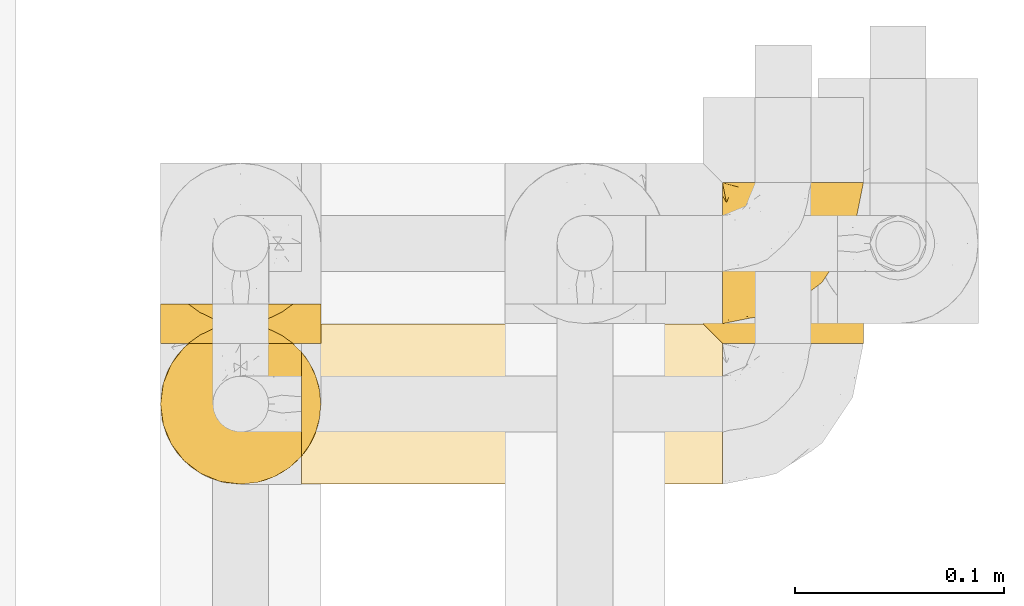
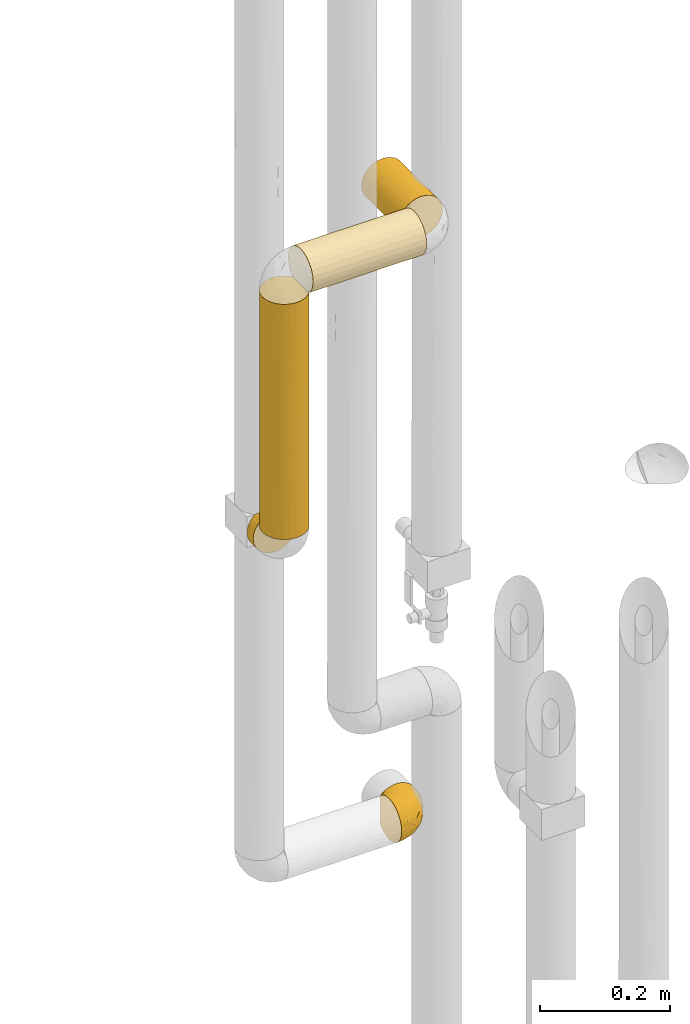
# One storey, part 288 of 827: 5 coverings.
"""IFC2X3 building model written with IfcOpenShell, lengths in millimetres."""

from ifc_helpers import new_model, entity, si_unit, converted_unit, derived_unit, direction, frame, origin, place, context, subcontext, project, spatial, faceted_brep, element, save


model = new_model("IFC2X3")

# Units and contexts
model_context = context("Model", 3, precision=0.01, world=origin(), true_north=direction((6.12303176911189e-17, 1.0)))
body_context = subcontext(model_context, "Body", "Model", "MODEL_VIEW")
ifc_project = project(units=[si_unit("LENGTHUNIT", "METRE", prefix="MILLI"), si_unit("AREAUNIT", "SQUARE_METRE"), si_unit("VOLUMEUNIT", "CUBIC_METRE"), converted_unit("PLANEANGLEUNIT", "DEGREE", entity("IfcRatioMeasure", 0.0174532925199433), si_unit("PLANEANGLEUNIT", "RADIAN"), dimensions=[0, 0, 0, 0, 0, 0, 0]), si_unit("MASSUNIT", "GRAM", prefix="KILO"), derived_unit("MASSDENSITYUNIT", [(si_unit("MASSUNIT", "GRAM", prefix="KILO"), 1), (si_unit("LENGTHUNIT", "METRE"), -3)]), derived_unit("MOMENTOFINERTIAUNIT", [(si_unit("LENGTHUNIT", "METRE"), 4)]), si_unit("TIMEUNIT", "SECOND"), si_unit("FREQUENCYUNIT", "HERTZ"), si_unit("THERMODYNAMICTEMPERATUREUNIT", "DEGREE_CELSIUS"), derived_unit("THERMALTRANSMITTANCEUNIT", [(si_unit("MASSUNIT", "GRAM", prefix="KILO"), 1), (si_unit("THERMODYNAMICTEMPERATUREUNIT", "KELVIN"), -1), (si_unit("TIMEUNIT", "SECOND"), -3)]), derived_unit("VOLUMETRICFLOWRATEUNIT", [(si_unit("LENGTHUNIT", "METRE"), 3), (si_unit("TIMEUNIT", "SECOND"), -1)]), derived_unit("MASSFLOWRATEUNIT", [(si_unit("MASSUNIT", "GRAM", prefix="KILO"), 1), (si_unit("TIMEUNIT", "SECOND"), -1)]), derived_unit("ROTATIONALFREQUENCYUNIT", [(si_unit("TIMEUNIT", "SECOND"), -1)]), si_unit("ELECTRICCURRENTUNIT", "AMPERE"), si_unit("ELECTRICVOLTAGEUNIT", "VOLT"), si_unit("POWERUNIT", "WATT"), si_unit("FORCEUNIT", "NEWTON", prefix="KILO"), si_unit("ILLUMINANCEUNIT", "LUX"), si_unit("LUMINOUSFLUXUNIT", "LUMEN"), si_unit("LUMINOUSINTENSITYUNIT", "CANDELA"), derived_unit("USERDEFINED", [(si_unit("MASSUNIT", "GRAM", prefix="KILO"), -1), (si_unit("LENGTHUNIT", "METRE"), -2), (si_unit("TIMEUNIT", "SECOND"), 3), (si_unit("LUMINOUSFLUXUNIT", "LUMEN"), 1)]), derived_unit("LINEARVELOCITYUNIT", [(si_unit("LENGTHUNIT", "METRE"), 1), (si_unit("TIMEUNIT", "SECOND"), -1)]), si_unit("PRESSUREUNIT", "PASCAL"), derived_unit("USERDEFINED", [(si_unit("LENGTHUNIT", "METRE"), -2), (si_unit("MASSUNIT", "GRAM", prefix="KILO"), 1), (si_unit("TIMEUNIT", "SECOND"), -2)]), derived_unit("LINEARFORCEUNIT", [(si_unit("MASSUNIT", "GRAM", prefix="KILO"), 1), (si_unit("LENGTHUNIT", "METRE"), 1), (si_unit("TIMEUNIT", "SECOND"), -2), (si_unit("LENGTHUNIT", "METRE"), -1)]), derived_unit("PLANARFORCEUNIT", [(si_unit("MASSUNIT", "GRAM", prefix="KILO"), 1), (si_unit("LENGTHUNIT", "METRE"), 1), (si_unit("TIMEUNIT", "SECOND"), -2), (si_unit("LENGTHUNIT", "METRE"), -2)])], contexts=[model_context])

# Site, building, storey
site_placement = place(None, origin())
site = spatial("IfcSite", under=ifc_project, at=site_placement, CompositionType="ELEMENT")
building_placement = place(site_placement, origin())
building = spatial("IfcBuilding", under=site, at=building_placement, CompositionType="ELEMENT")
storey_placement = place(building_placement, frame((0.0, 0.0, 28200.0)))
storey = spatial("IfcBuildingStorey", under=building, at=storey_placement, Name="08", CompositionType="ELEMENT", Elevation=28200.0)

# Coverings
covering_1_placement = place(storey_placement, frame((35057.15, 15782.0, 1019.95)))
element("IfcCovering", 1, at=covering_1_placement, inside=storey, Name=":ADSK_", ObjectType=":ADSK_", PredefinedType="INSULATION", context=body_context, shape_type="Brep", body=[
    faceted_brep([(47.38, 69.15, 74.68), (54.67, 69.15, 70.1), (60.76, 69.15, 64.01), (65.34, 69.15, 56.72), (68.18, 69.15, 48.6), (69.15, 69.15, 40.05), (68.18, 69.15, 31.49), (65.33, 69.15, 23.36), (60.75, 69.15, 16.07), (54.66, 69.15, 9.98), (47.37, 69.15, 5.4), (39.25, 69.15, 2.56), (30.7, 69.15, 1.6), (22.59, 69.15, 2.46), (14.86, 69.15, 5.01), (7.84, 69.15, 9.13), (1.85, 69.15, 14.62), (1.85, 69.15, 16.82), (1.85, 69.15, 18.56), (1.85, 69.15, 20.52), (1.85, 69.15, 22.49), (1.85, 69.15, 24.46), (1.85, 69.15, 26.42), (1.85, 69.15, 28.39), (1.85, 69.15, 30.36), (1.85, 69.15, 32.55), (1.85, 69.15, 34.75), (1.85, 69.15, 36.94), (1.85, 69.15, 39.13), (1.85, 69.15, 41.33), (1.85, 69.15, 43.52), (1.85, 69.15, 45.72), (1.85, 69.15, 47.91), (1.85, 69.15, 50.11), (1.85, 69.15, 52.3), (1.85, 69.15, 54.49), (1.85, 69.15, 56.69), (1.85, 69.15, 58.88), (1.85, 69.15, 61.08), (1.85, 69.15, 63.27), (1.85, 69.15, 65.47), (7.85, 69.15, 70.97), (14.88, 69.15, 75.09), (22.61, 69.15, 77.64), (30.7, 69.15, 78.5), (39.26, 69.15, 77.53), (1.6, 68.89, 14.62), (1.6, 62.89, 9.12), (1.6, 55.87, 5.0), (1.6, 48.14, 2.46), (1.6, 40.05, 1.6), (1.6, 30.09, 2.91), (1.6, 20.82, 6.75), (1.6, 12.86, 12.86), (1.6, 6.75, 20.82), (1.6, 2.91, 30.09), (1.6, 1.6, 40.05), (1.6, 2.91, 50.0), (1.6, 6.75, 59.27), (1.6, 12.86, 67.23), (1.6, 20.82, 73.34), (1.6, 30.09, 77.19), (1.6, 40.05, 78.5), (1.6, 48.14, 77.63), (1.6, 55.87, 75.09), (1.6, 62.89, 70.97), (1.6, 68.89, 65.47), (1.6, 68.89, 63.27), (1.6, 68.89, 62.29), (1.6, 68.89, 60.7), (1.6, 68.89, 59.11), (1.6, 68.89, 57.52), (1.6, 68.89, 55.93), (1.6, 68.89, 54.34), (1.6, 68.89, 52.76), (1.6, 68.89, 51.17), (1.6, 68.89, 49.58), (1.6, 68.89, 47.99), (1.6, 68.89, 46.4), (1.6, 68.89, 44.81), (1.6, 68.89, 43.22), (1.6, 68.89, 41.63), (1.6, 68.89, 40.05), (1.6, 68.89, 38.46), (1.6, 68.89, 36.87), (1.6, 68.89, 35.28), (1.6, 68.89, 33.69), (1.6, 68.89, 32.1), (1.6, 68.89, 30.51), (1.6, 68.89, 28.92), (1.6, 68.89, 27.33), (1.6, 68.89, 25.37), (1.6, 68.89, 23.4), (1.6, 68.89, 21.21), (1.6, 68.89, 19.01), (1.6, 68.89, 16.82), (1.78, 68.97, 42.32), (1.77, 68.96, 44.02), (1.78, 68.97, 47.13), (1.77, 68.97, 48.74), (1.79, 68.98, 23.57), (1.78, 68.97, 25.13), (1.76, 68.96, 61.34), (1.77, 68.96, 22.02), (1.77, 68.96, 29.72), (1.76, 68.96, 56.73), (1.77, 68.96, 55.14), (1.77, 68.96, 37.66), (1.8, 69.0, 64.12), (1.76, 68.96, 28.13), (1.77, 68.96, 26.62), (1.78, 68.97, 31.46), (1.77, 68.96, 16.16), (1.77, 68.96, 39.16), (1.76, 68.96, 50.37), (1.77, 68.97, 17.69), (1.78, 68.97, 19.17), (1.77, 68.97, 62.78), (1.77, 68.96, 58.35), (1.77, 68.96, 45.53), (1.78, 68.97, 59.91), (1.77, 68.97, 65.47), (1.8, 69.02, 65.47), (1.82, 69.08, 65.47), (1.77, 68.97, 14.62), (1.72, 68.94, 14.62), (1.66, 68.92, 14.62), (1.76, 68.96, 20.59), (1.77, 68.96, 32.99), (1.76, 68.95, 34.48), (1.77, 68.96, 51.91), (1.66, 68.92, 65.47), (1.72, 68.94, 65.47), (1.78, 68.98, 53.48), (1.82, 69.08, 14.62), (1.8, 69.02, 14.62), (1.77, 68.96, 40.77), (1.78, 68.97, 35.97), (3.72, 61.33, 7.84), (7.41, 53.1, 3.53), (6.13, 63.33, 8.32), (21.47, 49.27, 1.6), (19.34, 55.53, 2.19), (26.8, 54.6, 1.6), (8.87, 41.99, 1.6), (9.2, 57.07, 4.57), (12.79, 57.95, 3.96), (14.62, 51.56, 2.28), (7.34, 41.58, 1.6), (5.33, 61.7, 7.69), (17.64, 63.33, 3.53), (7.7, 65.0, 8.32), (9.41, 67.02, 7.84), (28.75, 61.87, 1.6), (16.15, 43.94, 1.6), (14.14, 61.21, 4.34), (29.16, 63.4, 1.6), (57.02, 33.11, 29.63), (64.92, 52.82, 27.34), (64.0, 43.3, 40.05), (11.92, 33.73, 2.39), (19.16, 36.52, 2.43), (28.65, 24.87, 9.07), (24.62, 14.17, 16.64), (15.19, 18.43, 9.54), (18.36, 28.67, 4.52), (9.2, 26.0, 4.52), (46.98, 49.25, 7.49), (50.24, 59.72, 7.49), (56.1, 55.1, 12.85), (28.97, 44.72, 2.35), (54.46, 34.15, 22.66), (21.34, 5.25, 32.9), (18.4, 6.75, 25.33), (66.44, 55.54, 40.05), (12.07, 10.47, 16.64), (45.49, 25.49, 19.99), (50.57, 35.53, 16.37), (36.04, 48.22, 3.26), (42.07, 58.71, 3.75), (62.12, 57.42, 19.58), (37.37, 34.84, 7.5), (29.39, 36.87, 4.04), (53.59, 45.01, 13.94), (58.06, 44.4, 19.58), (49.27, 23.96, 28.21), (29.63, 11.2, 24.75), (33.21, 10.56, 31.42), (40.1, 16.81, 26.2), (44.08, 17.38, 33.36), (49.36, 21.38, 40.05), (56.68, 32.34, 40.05), (15.2, 4.3, 40.05), (35.57, 20.65, 16.14), (41.7, 29.66, 12.85), (46.4, 39.6, 10.47), (41.41, 42.55, 6.49), (27.45, 6.74, 40.05), (38.4, 14.06, 40.05), (12.99, 26.84, 75.57), (21.33, 5.28, 47.37), (42.89, 18.52, 52.91), (57.04, 33.13, 50.46), (56.11, 55.1, 67.23), (62.13, 57.43, 60.5), (21.89, 20.72, 70.55), (16.62, 11.46, 63.45), (32.9, 17.69, 62.61), (46.99, 49.26, 72.6), (50.25, 59.73, 72.6), (42.08, 58.71, 76.34), (49.91, 29.72, 59.34), (15.6, 35.35, 77.76), (16.15, 43.94, 78.5), (8.87, 41.99, 78.5), (29.16, 63.4, 78.5), (13.16, 4.93, 53.16), (10.83, 17.46, 70.55), (33.8, 10.94, 48.88), (25.02, 8.92, 54.76), (64.92, 52.83, 52.74), (32.83, 29.34, 71.93), (20.56, 30.26, 75.79), (58.07, 44.4, 60.5), (21.46, 39.06, 77.86), (28.1, 43.06, 77.64), (26.8, 54.6, 78.5), (21.47, 49.27, 78.5), (51.29, 42.69, 67.23), (36.04, 48.2, 76.82), (28.75, 61.87, 78.5), (8.45, 33.44, 77.8), (41.73, 29.67, 67.23), (39.27, 38.5, 73.2), (33.56, 23.35, 67.66), (27.29, 34.97, 75.99), (7.41, 53.1, 76.57), (3.51, 59.68, 73.21), (4.68, 62.19, 71.93), (5.52, 64.11, 71.07), (8.75, 57.97, 75.09), (12.79, 57.95, 76.13), (17.65, 63.33, 76.57), (13.9, 51.77, 77.69), (9.42, 67.02, 72.26), (7.68, 64.98, 71.77), (19.33, 55.53, 77.9), (14.13, 61.22, 75.75)], [[[0, 1, 2, 3, 4, 5, 6, 7, 8, 9, 10, 11, 12, 13, 14, 15, 16, 17, 18, 19, 20, 21, 22, 23, 24, 25, 26, 27, 28, 29, 30, 31, 32, 33, 34, 35, 36, 37, 38, 39, 40, 41, 42, 43, 44, 45]], [[46, 47, 48, 49, 50, 51, 52, 53, 54, 55, 56, 57, 58, 59, 60, 61, 62, 63, 64, 65, 66, 67, 68, 69, 70, 71, 72, 73, 74, 75, 76, 77, 78, 79, 80, 81, 82, 83, 84, 85, 86, 87, 88, 89, 90, 91, 92, 93, 94, 95]], [[96, 97, 30]], [[98, 77, 99]], [[100, 101, 21]], [[69, 68, 102]], [[20, 19, 103]], [[24, 23, 104]], [[20, 103, 100]], [[72, 105, 106]], [[84, 83, 107]], [[89, 88, 104]], [[108, 67, 66]], [[109, 110, 90]], [[111, 25, 24]], [[112, 17, 16]], [[82, 113, 83]], [[109, 23, 22]], [[114, 76, 75]], [[105, 36, 106]], [[104, 111, 24]], [[18, 115, 116]], [[97, 96, 80]], [[67, 108, 117]], [[105, 71, 118]], [[31, 97, 119]], [[102, 120, 69]], [[108, 121, 122, 123, 40]], [[112, 95, 115]], [[17, 115, 18]], [[94, 116, 115]], [[117, 68, 67]], [[38, 117, 39]], [[112, 124, 125, 126, 46]], [[17, 112, 115]], [[70, 120, 118]], [[39, 117, 108]], [[120, 38, 37]], [[120, 37, 118]], [[120, 70, 69]], [[116, 94, 127]], [[128, 86, 129]], [[117, 38, 102]], [[74, 130, 75]], [[99, 33, 32]], [[115, 95, 94]], [[39, 108, 40]], [[108, 66, 131, 132, 121]], [[105, 72, 71]], [[118, 37, 36]], [[71, 70, 118]], [[35, 106, 36]], [[36, 105, 118]], [[35, 133, 106]], [[74, 73, 133]], [[106, 133, 73]], [[99, 114, 33]], [[133, 35, 34]], [[73, 72, 106]], [[95, 112, 46]], [[112, 16, 134, 135, 124]], [[130, 114, 75]], [[99, 76, 114]], [[114, 130, 33]], [[34, 33, 130]], [[78, 77, 98]], [[98, 119, 78]], [[130, 133, 34]], [[133, 130, 74]], [[79, 97, 80]], [[98, 99, 32]], [[98, 32, 31]], [[77, 76, 99]], [[97, 79, 119]], [[136, 96, 29]], [[30, 97, 31]], [[136, 29, 28]], [[81, 80, 96]], [[29, 96, 30]], [[31, 119, 98]], [[119, 79, 78]], [[96, 136, 81]], [[82, 81, 136]], [[113, 107, 83]], [[84, 107, 137]], [[107, 27, 137]], [[113, 28, 107]], [[27, 107, 28]], [[85, 84, 137]], [[137, 27, 26]], [[113, 136, 28]], [[136, 113, 82]], [[109, 89, 104]], [[86, 85, 129]], [[89, 109, 90]], [[111, 87, 128]], [[26, 129, 137]], [[88, 111, 104]], [[25, 111, 128]], [[22, 110, 109]], [[23, 109, 104]], [[110, 91, 90]], [[100, 92, 101]], [[110, 22, 101]], [[91, 110, 101]], [[116, 19, 18]], [[111, 88, 87]], [[127, 103, 19]], [[25, 128, 26]], [[86, 128, 87]], [[128, 129, 26]], [[137, 129, 85]], [[120, 102, 38]], [[117, 102, 68]], [[91, 101, 92]], [[21, 101, 22]], [[93, 92, 103]], [[100, 21, 20]], [[100, 103, 92]], [[127, 93, 103]], [[93, 127, 94]], [[116, 127, 19]], [[126, 138, 47]], [[48, 138, 139]], [[140, 125, 124]], [[141, 142, 143]], [[144, 49, 139]], [[145, 140, 146]], [[48, 139, 49]], [[139, 145, 147]], [[49, 144, 148, 50]], [[126, 125, 149]], [[14, 13, 150]], [[151, 146, 140]], [[149, 140, 145]], [[152, 151, 135]], [[152, 14, 150]], [[16, 15, 134]], [[13, 153, 150]], [[124, 151, 140]], [[141, 147, 142]], [[14, 152, 15]], [[15, 152, 134]], [[47, 46, 126]], [[139, 154, 144]], [[138, 48, 47]], [[125, 140, 149]], [[135, 134, 152]], [[146, 155, 142]], [[145, 146, 147]], [[149, 139, 138]], [[147, 141, 154]], [[147, 146, 142]], [[139, 147, 154]], [[139, 149, 145]], [[149, 138, 126]], [[155, 146, 151]], [[150, 143, 142]], [[152, 155, 151]], [[150, 142, 155]], [[13, 12, 156, 153]], [[153, 143, 150]], [[152, 150, 155]], [[151, 124, 135]], [[157, 158, 159]], [[160, 154, 161]], [[162, 163, 164]], [[165, 166, 160]], [[167, 168, 169]], [[141, 170, 161]], [[156, 12, 11]], [[158, 157, 171]], [[172, 55, 173]], [[158, 6, 174]], [[175, 54, 53]], [[52, 166, 164]], [[52, 164, 53]], [[54, 175, 173]], [[166, 52, 51]], [[176, 177, 171]], [[178, 143, 179]], [[156, 11, 179]], [[8, 7, 180]], [[169, 9, 8]], [[179, 143, 153, 156]], [[179, 11, 10]], [[168, 179, 10]], [[181, 162, 182]], [[179, 167, 178]], [[183, 184, 177]], [[183, 169, 184]], [[176, 171, 185]], [[172, 186, 187]], [[158, 7, 6]], [[159, 158, 174]], [[184, 180, 158]], [[54, 173, 55]], [[180, 169, 8]], [[188, 189, 187]], [[9, 168, 10]], [[186, 188, 187]], [[190, 157, 159, 191]], [[55, 172, 192]], [[176, 193, 194]], [[161, 170, 182]], [[162, 164, 165]], [[175, 164, 163]], [[51, 50, 148]], [[167, 195, 196]], [[178, 182, 170]], [[6, 5, 174]], [[158, 180, 7]], [[169, 180, 184]], [[169, 168, 9]], [[179, 168, 167]], [[182, 162, 165]], [[162, 194, 193]], [[161, 165, 160]], [[195, 181, 196]], [[192, 172, 197]], [[192, 56, 55]], [[189, 190, 198]], [[198, 197, 187]], [[172, 187, 197]], [[185, 189, 188]], [[198, 187, 189]], [[186, 172, 173]], [[173, 163, 186]], [[193, 186, 163]], [[176, 185, 188]], [[185, 157, 190]], [[188, 186, 193]], [[177, 176, 194]], [[188, 193, 176]], [[162, 193, 163]], [[195, 177, 194]], [[171, 177, 184]], [[181, 195, 194]], [[183, 167, 169]], [[162, 181, 194]], [[196, 182, 178]], [[158, 171, 184]], [[171, 157, 185]], [[177, 195, 183]], [[167, 183, 195]], [[182, 196, 181]], [[178, 170, 143]], [[178, 167, 196]], [[164, 175, 53]], [[173, 175, 163]], [[160, 51, 148]], [[164, 166, 165]], [[51, 160, 166]], [[160, 148, 144, 154]], [[141, 161, 154]], [[182, 165, 161]], [[190, 189, 185]], [[143, 170, 141]], [[60, 199, 61]], [[197, 200, 192]], [[201, 190, 202]], [[200, 57, 192]], [[203, 204, 2]], [[205, 206, 207]], [[208, 209, 210]], [[211, 207, 201]], [[212, 213, 214]], [[45, 215, 210]], [[216, 206, 58]], [[45, 44, 215]], [[59, 217, 60]], [[60, 217, 199]], [[0, 45, 210]], [[218, 201, 219]], [[202, 159, 220]], [[205, 221, 222]], [[223, 204, 203]], [[1, 203, 2]], [[57, 200, 216]], [[220, 3, 204]], [[220, 174, 4]], [[1, 0, 209]], [[212, 224, 213]], [[225, 226, 227]], [[228, 223, 203]], [[208, 210, 229]], [[210, 226, 229]], [[3, 220, 4]], [[58, 206, 59]], [[209, 203, 1]], [[202, 220, 223]], [[228, 203, 208]], [[202, 211, 201]], [[3, 2, 204]], [[202, 190, 191, 159]], [[210, 215, 230, 226]], [[199, 212, 231]], [[232, 233, 221]], [[233, 208, 229]], [[207, 206, 219]], [[217, 206, 205]], [[227, 224, 225]], [[233, 232, 228]], [[201, 207, 219]], [[234, 232, 221]], [[218, 219, 200]], [[202, 223, 211]], [[174, 220, 159]], [[174, 5, 4]], [[61, 231, 62]], [[220, 204, 223]], [[210, 209, 0]], [[203, 209, 208]], [[225, 233, 229]], [[224, 227, 213]], [[221, 233, 235]], [[57, 56, 192]], [[198, 218, 197]], [[200, 219, 216]], [[201, 198, 190]], [[197, 218, 200]], [[198, 201, 218]], [[206, 216, 219]], [[58, 57, 216]], [[231, 212, 214]], [[222, 212, 199]], [[228, 211, 223]], [[207, 211, 232]], [[62, 231, 214]], [[199, 231, 61]], [[233, 228, 208]], [[211, 228, 232]], [[222, 221, 235]], [[234, 205, 207]], [[206, 217, 59]], [[199, 217, 205]], [[205, 222, 199]], [[224, 222, 235]], [[222, 224, 212]], [[224, 235, 225]], [[233, 225, 235]], [[226, 225, 229]], [[205, 234, 221]], [[207, 232, 234]], [[63, 214, 236]], [[214, 213, 236]], [[214, 63, 62]], [[237, 236, 238]], [[238, 132, 131]], [[236, 237, 64]], [[239, 240, 241]], [[63, 236, 64]], [[131, 66, 65]], [[237, 131, 65]], [[242, 230, 43]], [[237, 65, 64]], [[239, 121, 132]], [[42, 242, 43]], [[241, 240, 243]], [[41, 123, 244]], [[43, 230, 215, 44]], [[244, 122, 245]], [[227, 246, 243]], [[241, 247, 245]], [[121, 239, 245]], [[41, 40, 123]], [[132, 238, 239]], [[244, 42, 41]], [[131, 237, 238]], [[240, 239, 238]], [[245, 239, 241]], [[247, 241, 246]], [[247, 244, 245]], [[238, 236, 240]], [[243, 236, 213]], [[236, 243, 240]], [[227, 226, 246]], [[243, 213, 227]], [[242, 246, 226]], [[243, 246, 241]], [[246, 242, 247]], [[244, 247, 242]], [[242, 226, 230]], [[42, 244, 242]], [[122, 244, 123]], [[122, 121, 245]]]),
])
covering_2_placement = place(storey_placement, frame((34855.35, 15705.06, 2170.0)))
element("IfcCovering", 2, at=covering_2_placement, inside=storey, Name=":ADSK_", ObjectType=":ADSK_", PredefinedType="INSULATION", context=body_context, shape_type="Brep", body=[
    faceted_brep([(203.4, 63.08, 9.31), (203.4, 69.1, 14.94), (203.4, 69.1, 65.05), (203.4, 63.08, 70.68), (203.4, 56.01, 74.9), (203.4, 48.2, 77.51), (203.4, 40.0, 78.4), (203.4, 30.06, 77.09), (203.4, 20.8, 73.25), (203.4, 12.84, 67.15), (203.4, 6.74, 59.2), (203.4, 2.9, 49.93), (203.4, 1.6, 40.0), (203.4, 2.9, 30.06), (203.4, 6.74, 20.8), (203.4, 12.84, 12.84), (203.4, 20.8, 6.74), (203.4, 30.06, 2.9), (203.4, 40.0, 1.6), (203.4, 48.2, 2.48), (203.4, 56.01, 5.09), (1.6, 77.09, 49.93), (1.6, 78.4, 40.0), (1.6, 77.51, 31.79), (1.6, 74.9, 23.98), (1.6, 70.68, 16.91), (1.6, 65.05, 10.9), (1.6, 14.94, 10.9), (1.6, 9.31, 16.91), (1.6, 5.09, 23.98), (1.6, 2.48, 31.79), (1.6, 1.6, 40.0), (1.6, 2.9, 49.93), (1.6, 6.74, 59.2), (1.6, 12.84, 67.15), (1.6, 20.8, 73.25), (1.6, 30.06, 77.09), (1.6, 40.0, 78.4), (1.6, 49.93, 77.09), (1.6, 59.2, 73.25), (1.6, 67.15, 67.15), (1.6, 73.25, 59.2), (5.57, 20.48, 6.92), (8.5, 26.63, 4.0), (10.29, 33.21, 2.2), (10.9, 40.0, 1.6), (10.29, 46.78, 2.2), (8.5, 53.36, 4.0), (5.57, 59.51, 6.92), (199.42, 73.07, 20.48), (196.5, 76.0, 26.63), (194.7, 77.79, 33.21), (194.1, 78.4, 40.0), (194.7, 77.79, 46.78), (196.5, 76.0, 53.36), (199.42, 73.07, 59.51)], [[[0, 1, 2, 3, 4, 5, 6, 7, 8, 9, 10, 11, 12, 13, 14, 15, 16, 17, 18, 19, 20]], [[21, 22, 23, 24, 25, 26, 27, 28, 29, 30, 31, 32, 33, 34, 35, 36, 37, 38, 39, 40, 41]], [[31, 30, 12]], [[30, 29, 13]], [[14, 29, 28]], [[13, 12, 30]], [[14, 13, 29]], [[28, 15, 14]], [[28, 27, 15]], [[27, 42, 16]], [[43, 44, 17]], [[42, 43, 16]], [[16, 43, 17]], [[18, 17, 44]], [[45, 18, 44]], [[27, 16, 15]], [[46, 47, 19]], [[48, 26, 0]], [[47, 48, 20]], [[45, 46, 18]], [[19, 18, 46]], [[47, 20, 19]], [[48, 0, 20]], [[26, 1, 0]], [[49, 25, 24]], [[50, 24, 23]], [[51, 23, 22]], [[49, 1, 25]], [[51, 50, 23]], [[52, 51, 22]], [[49, 24, 50]], [[25, 1, 26]], [[53, 52, 22]], [[53, 22, 21]], [[54, 21, 41]], [[54, 53, 21]], [[2, 55, 41]], [[54, 41, 55]], [[41, 40, 2]], [[3, 40, 39]], [[4, 39, 38]], [[5, 38, 37]], [[3, 39, 4]], [[4, 38, 5]], [[37, 6, 5]], [[40, 3, 2]], [[7, 6, 37, 36]], [[8, 7, 36, 35]], [[35, 34, 9, 8]], [[11, 10, 33, 32]], [[12, 11, 32, 31]], [[34, 33, 10, 9]], [[51, 52, 53, 54, 55, 2, 1, 49, 50]], [[26, 48, 47, 46, 45, 44, 43, 42, 27]]]),
])
covering_3_placement = place(storey_placement, frame((35047.85, 15772.56, 2170.0)))
element("IfcCovering", 3, at=covering_3_placement, inside=storey, Name=":ADSK_", ObjectType=":ADSK_", PredefinedType="INSULATION", context=body_context, shape_type="Brep", body=[
    faceted_brep([(30.06, 119.49, 77.09), (40.0, 119.49, 78.4), (49.93, 119.49, 77.09), (59.2, 119.49, 73.25), (67.15, 119.49, 67.15), (73.25, 119.49, 59.2), (77.09, 119.49, 49.93), (78.4, 119.49, 40.0), (77.09, 119.49, 30.06), (73.25, 119.49, 20.8), (67.15, 119.49, 12.84), (59.2, 119.49, 6.74), (49.93, 119.49, 2.9), (40.0, 119.49, 1.6), (30.06, 119.49, 2.9), (20.8, 119.49, 6.74), (12.84, 119.49, 12.84), (6.74, 119.49, 20.8), (2.9, 119.49, 30.06), (1.6, 119.49, 40.0), (2.9, 119.49, 49.93), (6.74, 119.49, 59.2), (12.84, 119.49, 67.15), (20.8, 119.49, 73.25), (49.93, 1.6, 77.09), (40.0, 1.6, 78.4), (31.79, 1.6, 77.51), (23.98, 1.6, 74.9), (16.91, 1.6, 70.68), (10.9, 1.6, 65.05), (10.9, 1.6, 14.94), (16.91, 1.6, 9.31), (23.98, 1.6, 5.09), (31.79, 1.6, 2.48), (40.0, 1.6, 1.6), (49.93, 1.6, 2.9), (59.2, 1.6, 6.74), (67.15, 1.6, 12.84), (73.25, 1.6, 20.8), (77.09, 1.6, 30.06), (78.4, 1.6, 40.0), (77.09, 1.6, 49.93), (73.25, 1.6, 59.2), (67.15, 1.6, 67.15), (59.2, 1.6, 73.25), (6.92, 5.57, 20.48), (4.0, 8.5, 26.63), (2.2, 10.29, 33.21), (1.6, 10.9, 40.0), (2.2, 10.29, 46.78), (4.0, 8.5, 53.36), (6.92, 5.57, 59.51)], [[[0, 1, 2, 3, 4, 5, 6, 7, 8, 9, 10, 11, 12, 13, 14, 15, 16, 17, 18, 19, 20, 21, 22, 23]], [[24, 25, 26, 27, 28, 29, 30, 31, 32, 33, 34, 35, 36, 37, 38, 39, 40, 41, 42, 43, 44]], [[39, 38, 9, 8]], [[40, 39, 8, 7]], [[38, 37, 10, 9]], [[12, 11, 36, 35]], [[13, 12, 35, 34]], [[37, 36, 11, 10]], [[13, 34, 33]], [[14, 33, 32]], [[15, 32, 31]], [[13, 33, 14]], [[14, 32, 15]], [[31, 16, 15]], [[31, 30, 16]], [[30, 45, 17]], [[46, 47, 18]], [[45, 46, 17]], [[17, 46, 18]], [[19, 18, 47]], [[48, 19, 47]], [[30, 17, 16]], [[49, 50, 20]], [[51, 29, 21]], [[50, 51, 21]], [[48, 49, 19]], [[19, 49, 20]], [[50, 21, 20]], [[29, 22, 21]], [[23, 28, 27]], [[0, 27, 26]], [[1, 26, 25]], [[22, 28, 23]], [[23, 27, 0]], [[26, 1, 0]], [[28, 22, 29]], [[2, 1, 25, 24]], [[3, 2, 24, 44]], [[44, 43, 4, 3]], [[6, 5, 42, 41]], [[7, 6, 41, 40]], [[43, 42, 5, 4]], [[47, 46, 45, 30, 29, 51, 50, 49, 48]]]),
])
covering_4_placement = place(storey_placement, frame((34787.85, 15705.06, 1737.5)))
element("IfcCovering", 4, at=covering_4_placement, inside=storey, Name=":ADSK_", ObjectType=":ADSK_", PredefinedType="INSULATION", context=body_context, shape_type="Brep", body=[
    faceted_brep([(56.01, 5.09, 443.4), (63.08, 9.31, 443.4), (69.1, 14.94, 443.4), (69.1, 65.05, 443.4), (63.08, 70.68, 443.4), (56.01, 74.9, 443.4), (48.2, 77.51, 443.4), (40.0, 78.4, 443.4), (30.06, 77.09, 443.4), (20.8, 73.25, 443.4), (12.84, 67.15, 443.4), (6.74, 59.2, 443.4), (2.9, 49.93, 443.4), (1.6, 40.0, 443.4), (2.9, 30.06, 443.4), (6.74, 20.8, 443.4), (12.84, 12.84, 443.4), (20.8, 6.74, 443.4), (30.06, 2.9, 443.4), (40.0, 1.6, 443.4), (48.2, 2.48, 443.4), (78.4, 40.0, 1.6), (77.09, 30.06, 1.6), (73.25, 20.8, 1.6), (67.15, 12.84, 1.6), (59.2, 6.74, 1.6), (49.93, 2.9, 1.6), (40.0, 1.6, 1.6), (30.06, 2.9, 1.6), (20.8, 6.74, 1.6), (12.84, 12.84, 1.6), (6.74, 20.8, 1.6), (2.9, 30.06, 1.6), (1.6, 40.0, 1.6), (2.48, 48.2, 1.6), (5.09, 56.01, 1.6), (9.31, 63.08, 1.6), (14.94, 69.1, 1.6), (65.05, 69.1, 1.6), (70.68, 63.08, 1.6), (74.9, 56.01, 1.6), (77.51, 48.2, 1.6), (40.0, 1.6, 227.02), (40.0, 1.6, 217.97), (78.4, 40.0, 217.72), (77.02, 29.82, 229.68), (59.66, 7.01, 238.22), (52.17, 3.58, 233.35), (71.11, 17.49, 217.9), (65.94, 11.69, 244.29), (77.79, 33.21, 434.7), (76.0, 26.63, 436.5), (74.6, 23.36, 261.15), (78.4, 40.0, 434.1), (73.07, 20.48, 439.42), (71.12, 62.49, 232.0), (74.63, 56.58, 262.93), (77.79, 46.78, 434.7), (77.02, 50.17, 225.77), (59.51, 73.07, 5.57), (53.36, 76.0, 8.5), (56.58, 74.63, 182.06), (76.0, 53.36, 436.5), (73.07, 59.51, 439.42), (62.49, 71.12, 212.99), (46.78, 77.79, 10.29), (50.17, 77.02, 219.22), (40.0, 78.4, 10.9), (40.0, 78.4, 227.27), (20.48, 73.07, 5.57), (23.36, 74.6, 183.84), (26.63, 76.0, 8.5), (17.49, 71.11, 227.09), (29.82, 77.02, 215.31), (33.21, 77.79, 10.29), (11.69, 65.94, 200.7), (7.01, 59.66, 206.77), (3.58, 52.17, 211.64), (1.6, 40.0, 217.97), (1.6, 40.0, 227.02), (2.33, 32.5, 238.05), (4.52, 25.3, 222.5), (32.51, 2.33, 237.84), (25.3, 4.52, 222.5), (9.53, 16.62, 222.5), (16.62, 9.53, 222.5)], [[[0, 1, 2, 3, 4, 5, 6, 7, 8, 9, 10, 11, 12, 13, 14, 15, 16, 17, 18, 19, 20]], [[21, 22, 23, 24, 25, 26, 27, 28, 29, 30, 31, 32, 33, 34, 35, 36, 37, 38, 39, 40, 41]], [[26, 42, 43, 27]], [[44, 45, 22]], [[46, 47, 25]], [[48, 49, 24]], [[45, 50, 51]], [[26, 47, 42]], [[25, 47, 26]], [[20, 47, 0]], [[1, 0, 46]], [[42, 47, 20]], [[1, 46, 49]], [[20, 19, 42]], [[22, 45, 52]], [[23, 52, 48]], [[49, 46, 25]], [[53, 50, 44]], [[2, 49, 48]], [[44, 50, 45]], [[24, 23, 48]], [[2, 48, 54]], [[49, 2, 1]], [[54, 52, 51]], [[52, 54, 48]], [[21, 44, 22]], [[49, 25, 24]], [[52, 23, 22]], [[51, 52, 45]], [[47, 46, 0]], [[41, 44, 21]], [[55, 56, 40]], [[40, 39, 55]], [[57, 53, 44]], [[44, 41, 58]], [[59, 60, 61]], [[58, 56, 62]], [[3, 63, 55]], [[63, 62, 56]], [[58, 62, 57]], [[44, 58, 57]], [[55, 38, 64]], [[38, 59, 64]], [[38, 55, 39]], [[65, 66, 60]], [[65, 67, 68]], [[64, 4, 3]], [[66, 61, 60]], [[68, 66, 65]], [[64, 5, 4]], [[6, 68, 7]], [[61, 5, 64]], [[63, 56, 55]], [[40, 56, 58]], [[66, 68, 6]], [[5, 66, 6]], [[5, 61, 66]], [[3, 55, 64]], [[59, 61, 64]], [[40, 58, 41]], [[69, 70, 71]], [[10, 9, 72]], [[37, 72, 69]], [[73, 74, 71]], [[75, 37, 36]], [[72, 70, 69]], [[68, 74, 73]], [[68, 73, 8]], [[74, 68, 67]], [[8, 73, 70]], [[7, 68, 8]], [[9, 8, 70]], [[76, 36, 35]], [[9, 70, 72]], [[35, 34, 77]], [[75, 76, 11]], [[37, 75, 72]], [[12, 78, 79, 13]], [[34, 33, 78]], [[10, 72, 75]], [[77, 76, 35]], [[77, 11, 76]], [[78, 77, 34]], [[11, 77, 12]], [[75, 11, 10]], [[75, 36, 76]], [[71, 70, 73]], [[78, 12, 77]], [[80, 32, 81]], [[28, 82, 83]], [[80, 13, 79, 78, 33]], [[81, 32, 31]], [[80, 33, 32]], [[14, 81, 15]], [[81, 14, 80]], [[84, 16, 15]], [[84, 81, 31]], [[85, 84, 30]], [[82, 27, 43, 42, 19]], [[83, 29, 28]], [[82, 18, 83]], [[19, 18, 82]], [[85, 17, 16]], [[83, 85, 29]], [[27, 82, 28]], [[83, 17, 85]], [[84, 85, 16]], [[30, 84, 31]], [[17, 83, 18]], [[29, 85, 30]], [[13, 80, 14]], [[81, 84, 15]], [[2, 54, 51, 50, 53, 57, 62, 63, 3]], [[69, 71, 74, 67, 65, 60, 59, 38, 37]]]),
])
covering_5_placement = place(storey_placement, frame((34787.85, 15772.56, 1670.0)))
element("IfcCovering", 5, at=covering_5_placement, inside=storey, Name=":ADSK_", ObjectType=":ADSK_", PredefinedType="INSULATION", context=body_context, shape_type="Brep", body=[
    faceted_brep([(2.47, 20.49, 48.16), (5.06, 20.49, 55.94), (9.24, 20.49, 62.99), (14.82, 20.49, 69.0), (65.17, 20.49, 69.0), (70.75, 20.49, 62.99), (74.93, 20.49, 55.94), (77.52, 20.49, 48.16), (78.4, 20.49, 40.0), (77.52, 20.49, 31.83), (74.93, 20.49, 24.05), (70.75, 20.49, 17.0), (65.17, 20.49, 11.0), (14.82, 20.49, 11.0), (9.24, 20.49, 17.0), (5.06, 20.49, 24.05), (2.47, 20.49, 31.83), (1.6, 20.49, 40.0), (14.94, 1.6, 69.1), (9.31, 1.6, 63.08), (5.09, 1.6, 56.01), (2.48, 1.6, 48.2), (1.6, 1.6, 40.0), (2.9, 1.6, 30.06), (6.74, 1.6, 20.8), (12.84, 1.6, 12.84), (20.8, 1.6, 6.74), (30.06, 1.6, 2.9), (40.0, 1.6, 1.6), (49.93, 1.6, 2.9), (59.2, 1.6, 6.74), (67.15, 1.6, 12.84), (73.25, 1.6, 20.8), (77.09, 1.6, 30.06), (78.4, 1.6, 40.0), (77.51, 1.6, 48.2), (74.9, 1.6, 56.01), (70.68, 1.6, 63.08), (65.05, 1.6, 69.1), (46.78, 10.29, 77.79), (53.36, 8.5, 76.0), (46.82, 11.7, 77.78), (59.51, 5.57, 73.07), (59.61, 16.48, 73.01), (53.43, 13.52, 75.97), (40.0, 10.9, 78.4), (40.0, 11.09, 78.4), (53.43, 13.52, 4.02), (46.82, 11.7, 2.21), (40.0, 11.09, 1.6), (59.61, 16.48, 6.98), (33.17, 11.7, 2.21), (26.56, 13.52, 4.02), (20.38, 16.48, 6.98), (20.48, 5.57, 73.07), (20.38, 16.48, 73.01), (26.63, 8.5, 76.0), (33.21, 10.29, 77.79), (33.17, 11.7, 77.78), (26.56, 13.52, 75.97)], [[[0, 1, 2, 3, 4, 5, 6, 7, 8, 9, 10, 11, 12, 13, 14, 15, 16, 17]], [[18, 19, 20, 21, 22, 23, 24, 25, 26, 27, 28, 29, 30, 31, 32, 33, 34, 35, 36, 37, 38]], [[39, 40, 41]], [[42, 38, 43]], [[40, 42, 44]], [[45, 39, 46]], [[44, 41, 40]], [[43, 44, 42]], [[39, 41, 46]], [[38, 4, 43]], [[5, 37, 36]], [[6, 36, 35]], [[7, 35, 34]], [[4, 37, 5]], [[35, 7, 6]], [[6, 5, 36]], [[7, 34, 8]], [[37, 4, 38]], [[9, 34, 33]], [[33, 32, 10]], [[31, 11, 32]], [[8, 34, 9]], [[10, 9, 33]], [[11, 10, 32]], [[31, 12, 11]], [[47, 30, 29]], [[29, 28, 48]], [[49, 48, 28]], [[12, 31, 50]], [[48, 47, 29]], [[50, 30, 47]], [[50, 31, 30]], [[51, 49, 28]], [[51, 28, 27]], [[52, 27, 26]], [[52, 51, 27]], [[25, 13, 53]], [[52, 26, 53]], [[53, 26, 25]], [[14, 25, 24]], [[24, 23, 15]], [[22, 16, 23]], [[14, 24, 15]], [[16, 15, 23]], [[17, 16, 22]], [[25, 14, 13]], [[0, 22, 21]], [[21, 20, 1]], [[19, 2, 20]], [[17, 22, 0]], [[20, 2, 1]], [[1, 0, 21]], [[2, 19, 3]], [[19, 18, 3]], [[18, 54, 55]], [[56, 57, 58]], [[54, 56, 59]], [[59, 55, 54]], [[57, 46, 58]], [[46, 57, 45]], [[59, 56, 58]], [[18, 55, 3]], [[50, 47, 48, 49, 51, 52, 53, 13, 12]], [[55, 59, 58, 46, 41, 44, 43, 4, 3]], [[40, 39, 45, 57, 56, 54, 18, 38, 42]]]),
])

save(model, "model.ifc")
